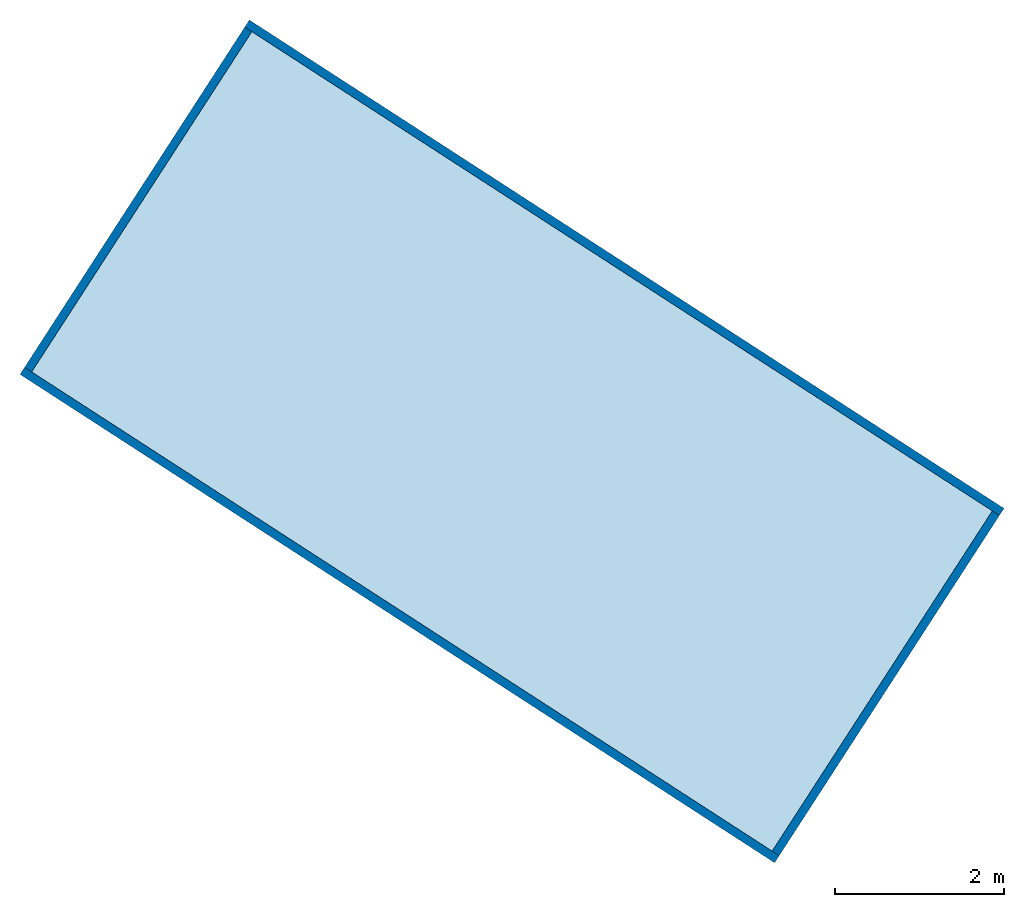
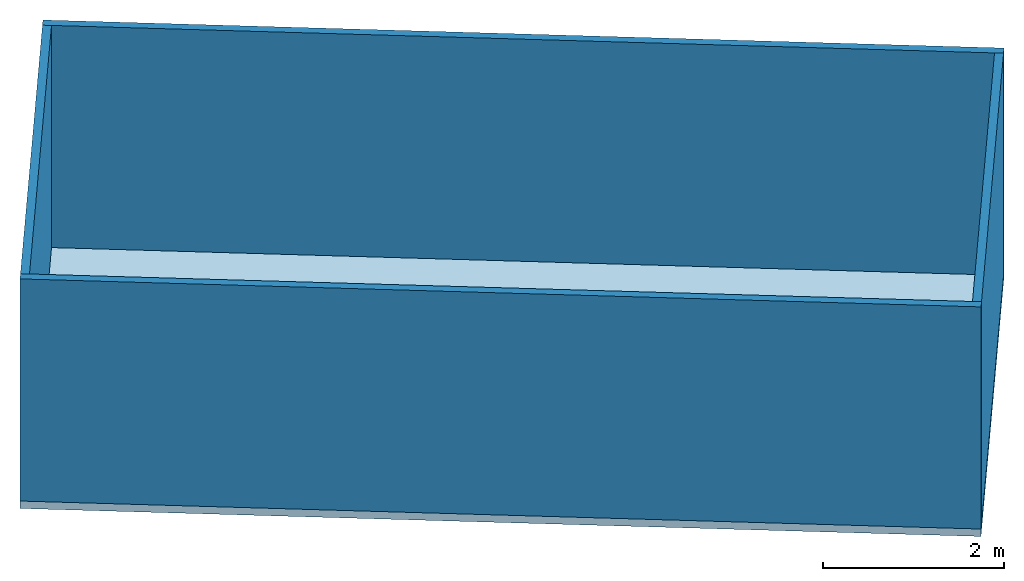
# One storey: 4 walls, 1 slab.
"""IFC4 building model written with IfcOpenShell, lengths in metres."""

from ifc_helpers import new_model, entity, si_unit, converted_unit, frame, origin_with_axes, origin_2d_with_axis, place, context, subcontext, project, spatial, line, indexed_curve, outline, extrude, material, layer, layer_set, layer_usage, type_object, element, save


model = new_model("IFC4")

# Units and contexts
model_context = context("Model", 3, precision=1e-05, world=origin_with_axes())
plan_context = context("Plan", 2, precision=1e-05, world=origin_2d_with_axis())
body_context = subcontext(model_context, "Body", "Model", "MODEL_VIEW")
ifc_project = project(units=[si_unit("VOLUMEUNIT", "CUBIC_METRE"), si_unit("LENGTHUNIT", "METRE"), converted_unit("PLANEANGLEUNIT", "degree", entity("IfcReal", 0.0174532925199433), si_unit("PLANEANGLEUNIT", "RADIAN"), dimensions=[0, 0, 0, 0, 0, 0, 0]), si_unit("AREAUNIT", "SQUARE_METRE")], contexts=[model_context, plan_context])

# Site, building, storey
site_placement = place(None, origin_with_axes())
site = spatial("IfcSite", under=ifc_project, at=site_placement)
building_placement = place(site_placement, origin_with_axes())
building = spatial("IfcBuilding", under=site, at=building_placement, Name="Building2")
storey_placement = place(building_placement, origin_with_axes())
storey = spatial("IfcBuildingStorey", under=building, at=storey_placement, Name="Storey")

# Slab
ifc_material = material()
ifc_layer_1 = layer(ifc_material, 0.1)
ifc_layer_set_1 = layer_set([ifc_layer_1])
ifc_layer_usage_1 = layer_usage(ifc_layer_set_1, "AXIS3", "POSITIVE", 0.0)
slab_type = type_object("IfcSlabType", Name="SLB-01", PredefinedType="FLOOR", material=ifc_layer_set_1)
slab_placement = place(storey_placement, frame((18.6137504577637, 36.112850189209, -0.100000001490116), z_axis=(0.0, 0.0, 1.0), x_axis=(0.839522977490462, -0.543324185238932, 0.0)))
element("IfcSlab", 1, at=slab_placement, inside=storey, type_object=slab_type, material=ifc_layer_usage_1, Name="Slab", context=body_context, shape_type="SweptSolid", body=[
    extrude(outline(indexed_curve([(0.0, 0.0), (10.64599609375, 0.0), (10.64599609375, 5.0), (0.0, 5.0)], segments=[line(3, 2), line(2, 1), line(1, 4), line(4, 3)], self_intersect=False)), None, (0.0, 0.0, 1.0), 0.1),
])

# Walls
ifc_layer_2 = layer(ifc_material, 0.1)
ifc_layer_set_2 = layer_set([ifc_layer_2])
ifc_layer_usage_2 = layer_usage(ifc_layer_set_2, "AXIS2", "POSITIVE", 0.0)
wall_type = type_object("IfcWallType", Name="WAL-01", PredefinedType="SOLIDWALL", material=ifc_layer_set_2)
wall_1_placement = place(storey_placement, frame((27.6056365966797, 30.4125747680664, 0.0), z_axis=(0.0, 0.0, 1.0), x_axis=(0.543324449660621, 0.839522806361437, 0.0)))
element("IfcWall", 2, at=wall_1_placement, inside=storey, type_object=wall_type, material=ifc_layer_usage_2, Name="Wall", context=body_context, shape_type="SweptSolid", body=[
    extrude(outline(indexed_curve([(0.0, 0.0), (0.0, 0.1), (4.799999300639, 0.1), (4.799999300639, 0.0), (0.0, 0.0)], self_intersect=False)), origin_with_axes(), (0.0, 0.0, 1.0), 3.0),
])
ifc_layer_usage_3 = layer_usage(ifc_layer_set_2, "AXIS2", "POSITIVE", 0.0)
wall_2_placement = place(storey_placement, frame((27.6056385040283, 30.4125747680664, 0.0), z_axis=(0.0, 0.0, 1.0), x_axis=(-0.839522950302808, 0.543324227248215, 0.0)))
element("IfcWall", 3, at=wall_2_placement, inside=storey, type_object=wall_type, material=ifc_layer_usage_3, Name="Wall", context=body_context, shape_type="SweptSolid", body=[
    extrude(outline(indexed_curve([(0.0, 0.0), (0.0, 0.1), (10.645996172133, 0.1), (10.645996172133, 0.0), (0.0, 0.0)], self_intersect=False)), origin_with_axes(), (0.0, 0.0, 1.0), 3.0),
])
ifc_layer_usage_4 = layer_usage(ifc_layer_set_2, "AXIS2", "POSITIVE", 0.0)
wall_3_placement = place(storey_placement, frame((30.2679290771484, 34.526237487793, 0.0), z_axis=(0.0, 0.0, 1.0), x_axis=(-0.839522950302808, 0.543324227248215, 0.0)))
element("IfcWall", 4, at=wall_3_placement, inside=storey, type_object=wall_type, material=ifc_layer_usage_4, Name="Wall", context=body_context, shape_type="SweptSolid", body=[
    extrude(outline(indexed_curve([(0.0, 0.0), (0.0, 0.1), (10.645996172133, 0.1), (10.645996172133, 0.0), (0.0, 0.0)], self_intersect=False)), origin_with_axes(), (0.0, 0.0, 1.0), 3.0),
])
ifc_layer_usage_5 = layer_usage(ifc_layer_set_2, "AXIS2", "POSITIVE", 0.0)
wall_4_placement = place(storey_placement, frame((18.7520332336426, 36.1424713134766, 0.0), z_axis=(0.0, 0.0, 1.0), x_axis=(0.543324449660621, 0.839522806361437, 0.0)))
element("IfcWall", 5, at=wall_4_placement, inside=storey, type_object=wall_type, material=ifc_layer_usage_5, Name="Wall", context=body_context, shape_type="SweptSolid", body=[
    extrude(outline(indexed_curve([(0.0, 0.0), (0.0, 0.1), (4.799999300639, 0.1), (4.799999300639, 0.0), (0.0, 0.0)], self_intersect=False)), origin_with_axes(), (0.0, 0.0, 1.0), 3.0),
])

save(model, "model.ifc")
